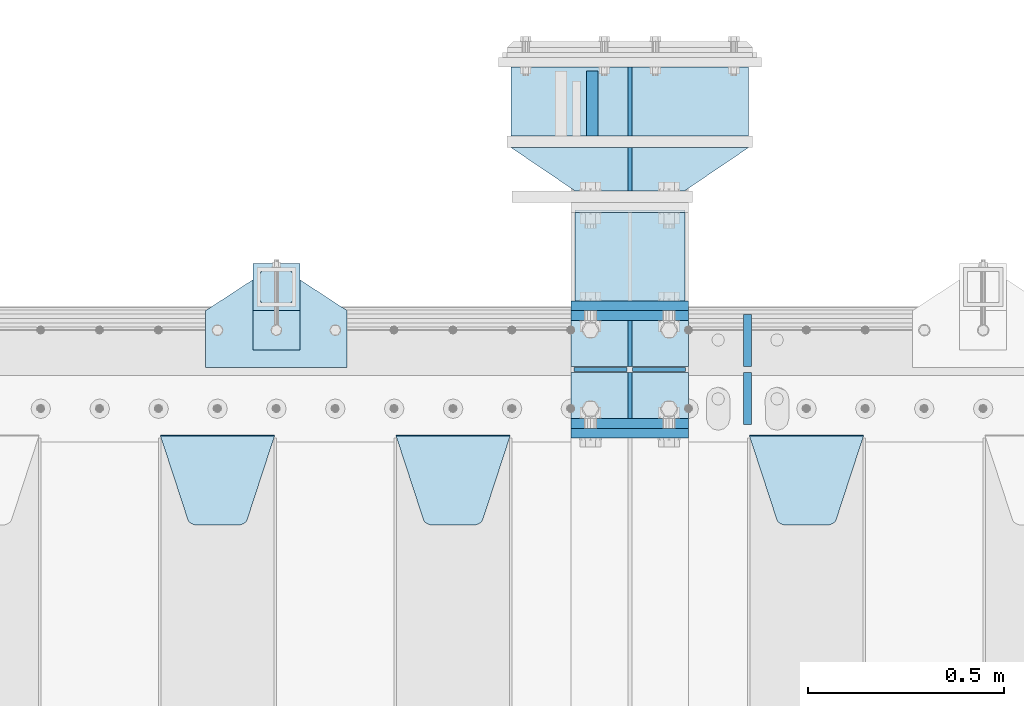
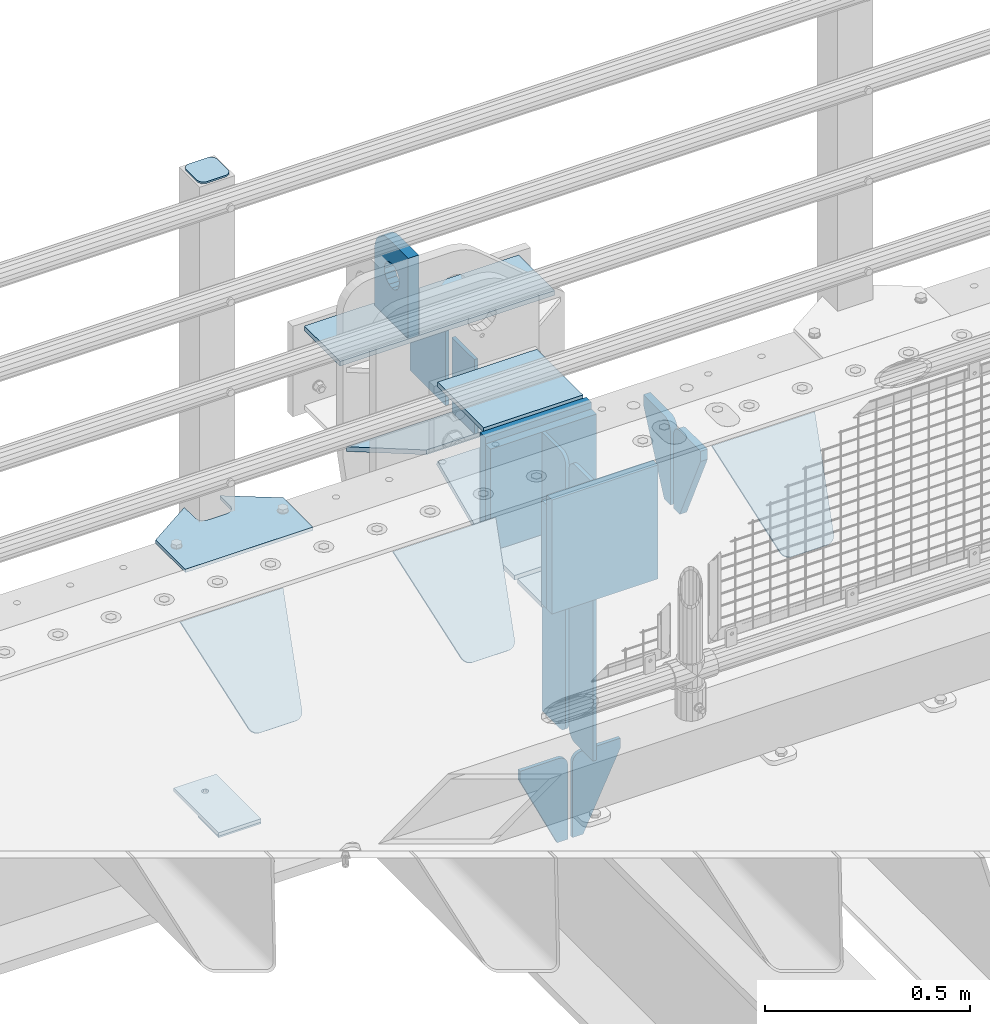
# One storey, part 186 of 208: 28 plates.
"""IFC2X3 building model written with IfcOpenShell, lengths in millimetres."""

import ifcopenshell
import ifcopenshell.guid

model = None  # the IFC model being written
_history = None  # IfcOwnerHistory: only IFC2X3 demands one
_inside = {}  # id of a spatial element -> (the spatial element, [elements in it])
_under = {}  # id of a project, library or spatial element -> (it, [spatial elements below it])
_declared = {}  # id of a project -> (the project, [libraries it declares])
_typed = {}  # id of a type object -> (the type object, [elements of that type])
_made_of = {}  # id of a material, layer set ... -> (it, [elements and type objects made of it])


def new_model(schema):
    """Start an empty IFC model of exactly this schema.

    Asked for "IFC4X3", IfcOpenShell would pick the latest addendum, in which some entities
    have other attributes; the version numbers below select the first issue.
    IFC2X3 requires an IfcOwnerHistory on every rooted entity: one is made here for all.
    """
    global model, _history
    if schema == "IFC4X3":
        model = ifcopenshell.file(schema_version=(4, 3, 0, 0))
    else:
        model = ifcopenshell.file(schema=schema)
    _inside.clear()
    _under.clear()
    _declared.clear()
    _typed.clear()
    _made_of.clear()
    _history = None
    if model.schema == "IFC2X3":
        org = make("IfcOrganization", Name="unknown")
        user = make(
            "IfcPersonAndOrganization",
            ThePerson=make("IfcPerson", FamilyName="unknown"),
            TheOrganization=org,
        )
        app = make(
            "IfcApplication",
            ApplicationDeveloper=org,
            Version="unknown",
            ApplicationFullName="unknown",
            ApplicationIdentifier="unknown",
        )
        _history = make(
            "IfcOwnerHistory",
            OwningUser=user,
            OwningApplication=app,
            ChangeAction="ADDED",
            CreationDate=0,
        )
    return model


def make(cls, **values):
    """One entity of the class cls with the attributes given. An attribute that is None is left unset."""
    return model.create_entity(
        cls, **{name: value for name, value in values.items() if value is not None}
    )


def rooted(cls, **values):
    """An entity with a GlobalId (a new one), such as an element, a storey or a relation."""
    return make(cls, GlobalId=ifcopenshell.guid.new(), OwnerHistory=_history, **values)


def si_unit(unit_type, name, prefix=None):
    """IfcSIUnit, for example si_unit("LENGTHUNIT", "METRE", prefix="MILLI")."""
    return make("IfcSIUnit", UnitType=unit_type, Prefix=prefix, Name=name)


def assignment(units):
    """IfcUnitAssignment: the units of a project."""
    return None if units is None else make("IfcUnitAssignment", Units=units)


def point(xyz):
    """IfcCartesianPoint."""
    return None if xyz is None else make("IfcCartesianPoint", Coordinates=xyz)


def direction(xyz):
    """IfcDirection."""
    return None if xyz is None else make("IfcDirection", DirectionRatios=xyz)


def frame(location, z_axis=None, x_axis=None):
    """IfcAxis2Placement3D, a coordinate frame: its origin and axes. An axis left out is left unset."""
    return make(
        "IfcAxis2Placement3D",
        Location=point(location),
        Axis=direction(z_axis),
        RefDirection=direction(x_axis),
    )


def origin_with_axes():
    """The frame at (0, 0, 0) with the z axis (0, 0, 1) and the x axis (1, 0, 0) written out."""
    return frame((0.0, 0.0, 0.0), z_axis=(0.0, 0.0, 1.0), x_axis=(1.0, 0.0, 0.0))


def place(relative_to, where):
    """IfcLocalPlacement: puts the frame where relative to a parent placement (None: the world)."""
    return make(
        "IfcLocalPlacement", PlacementRelTo=relative_to, RelativePlacement=where
    )


def context(
    kind, dimensions, precision=None, world=None, true_north=None, identifier=None
):
    """IfcGeometricRepresentationContext, for example the 3D "Model" context."""
    return make(
        "IfcGeometricRepresentationContext",
        ContextIdentifier=identifier,
        ContextType=kind,
        CoordinateSpaceDimension=dimensions,
        Precision=precision,
        WorldCoordinateSystem=world,
        TrueNorth=true_north,
    )


def subcontext(parent, identifier, kind, view, scale=None):
    """IfcGeometricRepresentationSubContext, for example "Body" below "Model"."""
    return make(
        "IfcGeometricRepresentationSubContext",
        ContextIdentifier=identifier,
        ContextType=kind,
        ParentContext=parent,
        TargetScale=scale,
        TargetView=view,
    )


def project(units=None, contexts=None):
    """IfcProject with its units and contexts."""
    return rooted(
        "IfcProject",
        Name="project",
        RepresentationContexts=contexts,
        UnitsInContext=assignment(units),
    )


def spatial(cls, under=None, at=None, **own):
    """A site, building, storey or space (cls), placed at a placement, below another one or the project."""
    s = rooted(cls, ObjectPlacement=at, **own)
    if under is not None:
        _under.setdefault(under.id(), (under, []))[1].append(s)
    return s


def faces_of(points, faces, orient=None, outer=None):
    """IfcFace entities. A face is a list of loops; a loop is a list of indices into points, from 0.

    orient and outer hold one flag for each loop. By default every Orientation is true, the
    first loop of a face is its IfcFaceOuterBound and the others are IfcFaceBound.
    """
    made = []
    for i, loops in enumerate(faces):
        bounds = []
        for j, loop in enumerate(loops):
            is_outer = j == 0 if outer is None else outer[i][j]
            bounds.append(
                make(
                    "IfcFaceOuterBound" if is_outer else "IfcFaceBound",
                    Bound=make("IfcPolyLoop", Polygon=[points[k] for k in loop]),
                    Orientation=True if orient is None else orient[i][j],
                )
            )
        made.append(make("IfcFace", Bounds=bounds))
    return made


def faceted_brep(points, faces, orient=None, outer=None, voids=None):
    """IfcFacetedBrep: a solid bounded by flat faces; with voids (closed shells), ...WithVoids."""
    shared = [point(p) for p in points]
    hull = make("IfcClosedShell", CfsFaces=faces_of(shared, faces, orient, outer))
    if voids is None:
        return make("IfcFacetedBrep", Outer=hull)
    return make(
        "IfcFacetedBrepWithVoids",
        Outer=hull,
        Voids=[
            make(cls, CfsFaces=faces_of(shared, fs, o, b)) for cls, fs, o, b in voids
        ],
    )


def shape(context_of_items, identifier, shape_type, items):
    """IfcShapeRepresentation: the items that make up one representation, for example the "Body"."""
    return make(
        "IfcShapeRepresentation",
        ContextOfItems=context_of_items,
        RepresentationIdentifier=identifier,
        RepresentationType=shape_type,
        Items=items,
    )


def material(Name=None, Category=None):
    """IfcMaterial."""
    return make("IfcMaterial", Name=Name, Category=Category)


def made_of(thing, what):
    """Note that an element or type object is made of a material, layer set ...; save() writes the relation."""
    if what is not None:
        _made_of.setdefault(what.id(), (what, []))[1].append(thing)
    return thing


def type_object(cls, material=None, **own):
    """A type object (cls), such as IfcWallType, which elements share."""
    return made_of(rooted(cls, **own), material)


def element(
    cls,
    number,
    at=None,
    inside=None,
    cuts=None,
    type_object=None,
    material=None,
    context=None,
    identifier="Body",
    shape_type=None,
    held_by="IfcProductDefinitionShape",
    body=None,
    shapes=None,
    **own,
):
    """One element of the class cls, such as IfcWall. Its Tag is "e" and its number.

    at: its placement. inside: the storey or other place that contains it. cuts: it is an
    opening in that element (IfcRelVoidsElement). A single representation is given by context,
    identifier, shape_type and body (its items); several are given by shapes. held_by: the class
    of the entity that holds the representations. save() writes the other relations.
    """
    e = rooted(cls, Tag="e%d" % number, ObjectPlacement=at, **own)
    if body is not None:
        shapes = [shape(context, identifier, shape_type, body)]
    if shapes is not None:
        e.Representation = make(held_by, Representations=shapes)
    if inside is not None:
        _inside.setdefault(inside.id(), (inside, []))[1].append(e)
    if cuts is not None:
        rooted(
            "IfcRelVoidsElement", RelatingBuildingElement=cuts, RelatedOpeningElement=e
        )
    if type_object is not None:
        _typed.setdefault(type_object.id(), (type_object, []))[1].append(e)
    return made_of(e, material)


def aggregate(whole, parts):
    """IfcRelAggregates: a whole, such as a stair, and the parts it consists of."""
    return rooted("IfcRelAggregates", RelatingObject=whole, RelatedObjects=parts)


def save(model, path):
    """Write the relations noted so far, then the file.

    IfcRelAggregates (storeys below a building ...), IfcRelContainedInSpatialStructure (elements
    in a storey), IfcRelDefinesByType, IfcRelAssociatesMaterial and IfcRelDeclares: one each for
    every whole, place, type object, material and project.
    """
    for whole, parts in _under.values():
        aggregate(whole, parts)
    for where, things in _inside.values():
        rooted(
            "IfcRelContainedInSpatialStructure",
            RelatedElements=things,
            RelatingStructure=where,
        )
    for kind, things in _typed.values():
        rooted("IfcRelDefinesByType", RelatedObjects=things, RelatingType=kind)
    for what, things in _made_of.values():
        rooted("IfcRelAssociatesMaterial", RelatedObjects=things, RelatingMaterial=what)
    for by, libraries in _declared.values():
        rooted("IfcRelDeclares", RelatingContext=by, RelatedDefinitions=libraries)
    model.write(path)


model = new_model("IFC2X3")

# Units and contexts
model_context = context("Model", 3, precision=1e-05, world=origin_with_axes())
body_context = subcontext(model_context, "Body", "Model", "MODEL_VIEW")
ifc_project = project(units=[si_unit("LENGTHUNIT", "METRE", prefix="MILLI"), si_unit("AREAUNIT", "SQUARE_METRE"), si_unit("VOLUMEUNIT", "CUBIC_METRE"), si_unit("MASSUNIT", "GRAM", prefix="KILO"), si_unit("TIMEUNIT", "SECOND"), si_unit("PLANEANGLEUNIT", "RADIAN"), si_unit("SOLIDANGLEUNIT", "STERADIAN"), si_unit("THERMODYNAMICTEMPERATUREUNIT", "DEGREE_CELSIUS"), si_unit("LUMINOUSINTENSITYUNIT", "LUMEN")], contexts=[model_context])

# Site, building, storey
site_placement = place(None, origin_with_axes())
site = spatial("IfcSite", under=ifc_project, at=site_placement, CompositionType="ELEMENT")
building_placement = place(site_placement, origin_with_axes())
building = spatial("IfcBuilding", under=site, at=building_placement, Name="Standard", CompositionType="ELEMENT")
storey_placement = place(building_placement, origin_with_axes())
storey = spatial("IfcBuildingStorey", under=building, at=storey_placement, Name="Undefined", CompositionType="ELEMENT", Elevation=0.0)

# Plates
ifc_material_1 = material(Name="STEEL/S355N")
plate_type_1 = type_object("IfcPlateType", PredefinedType="NOTDEFINED")
plate_1_placement = place(storey_placement, frame((-30340.0000000603, 6175.00000003457, -7.00001822199147), z_axis=(0.0, 1.0, 0.0), x_axis=(1.0, 0.0, 0.0)))
element("IfcPlate", 1, at=plate_1_placement, inside=storey, type_object=plate_type_1, material=ifc_material_1, context=body_context, shape_type="Brep", body=[
    faceted_brep([(0.0, -7.0, 0.0), (0.0, -7.0, 225.0), (0.0, 7.0, 225.0), (0.0, 7.0, 0.0), (280.0, -7.0, 225.0), (280.0, 7.0, 225.0), (280.0, -7.0, 0.0), (280.0, 7.0, 0.0)], [[[0, 1, 2, 3]], [[1, 4, 5, 2]], [[4, 6, 7, 5]], [[6, 0, 3, 7]], [[5, 7, 3, 2]], [[6, 4, 1, 0]]]),
])
plate_type_2 = type_object("IfcPlateType", PredefinedType="NOTDEFINED")
plate_2_placement = place(storey_placement, frame((-30200.0000000603, 6770.00000003457, -14.0000182219915), z_axis=(0.0, 0.0, -1.0), x_axis=(0.0, -1.0, 0.0)))
element("IfcPlate", 2, at=plate_2_placement, inside=storey, type_object=plate_type_2, material=ifc_material_1, context=body_context, shape_type="Brep", body=[
    faceted_brep([(0.0, -5.0, 0.0), (0.0, -5.0, 222.0), (0.0, 5.0, 222.0), (0.0, 5.0, 0.0), (175.0, -5.0, 222.0), (175.0, 5.0, 222.0), (175.0, -5.0, 0.0), (175.0, 5.0, 0.0)], [[[0, 1, 2, 3]], [[1, 4, 5, 2]], [[4, 6, 7, 5]], [[6, 0, 3, 7]], [[5, 7, 3, 2]], [[6, 4, 1, 0]]]),
])
plate_type_3 = type_object("IfcPlateType", PredefinedType="NOTDEFINED")
plate_3_placement = place(storey_placement, frame((-30295.5000000603, 6595.00000003457, -1.82219914677262e-05), z_axis=(0.0, 1.0, 0.0), x_axis=(0.0, 0.0, 1.0)))
element("IfcPlate", 3, at=plate_3_placement, inside=storey, type_object=plate_type_3, material=ifc_material_1, context=body_context, shape_type="Brep", body=[
    faceted_brep([(113.837049096103, -14.9999989400749, 106.162951053903), (113.837049096103, 15.0000010599251, 106.162950753903), (125.840713002497, 15.0000011401316, 114.183542552919), (125.840713002497, -14.9999988598684, 114.183542852919), (105.816457297088, -14.99999906011, 94.1592871475093), (105.816457297088, 15.00000093989, 94.1592868475093), (103.000000000005, -14.9999992017038, 80.000000150001), (103.000000000005, 15.0000007982962, 79.999999850001), (105.816457297088, -14.9999993432975, 65.8407131524926), (105.816457297088, 15.0000006567025, 65.8407128524926), (113.837049096103, -14.9999994633326, 53.8370492460988), (113.837049096103, 15.0000005366674, 53.8370489460988), (125.840713002497, -14.9999995435392, 45.8164574470834), (125.840713002497, 15.0000004564608, 45.8164571470834), (140.000000000005, -14.9999995717044, 43.000000150001), (140.000000000005, 15.0000004282956, 42.999999850001), (154.159286997514, -14.9999995435392, 45.8164574470834), (154.159286997514, 15.0000004564608, 45.8164571470834), (166.162950903908, -14.9999994633326, 53.8370492460988), (166.162950903908, 15.0000005366674, 53.8370489460988), (174.183542702923, -14.9999993432975, 65.8407131524928), (174.183542702923, 15.0000006567025, 65.8407128524927), (177.000000000005, -14.9999992017038, 80.000000150001), (177.000000000005, 15.0000007982962, 79.999999850001), (174.183542702923, -14.99999906011, 94.1592871475093), (174.183542702923, 15.00000093989, 94.1592868475093), (166.162950903908, -14.9999989400749, 106.162951053903), (166.162950903908, 15.0000010599251, 106.162950753903), (154.159286997514, -14.9999988598684, 114.183542852919), (154.159286997514, 15.0000011401316, 114.183542552919), (140.000000000005, -14.9999988317031, 117.000000150001), (140.000000000005, 15.0000011682969, 116.999999850001), (-1.40620068123098e-06, -15.0, 165.0), (170.0, -15.0, 165.0), (170.0, 15.0, 165.0), (-1.40620068123098e-06, 15.0, 165.0), (188.117333157176, -15.0, 162.614807840235), (188.117333157176, 15.0, 162.614807840235), (205.0, -15.0, 155.621778264911), (205.0, 15.0, 155.621778264911), (219.497474683058, -15.0, 144.497474683058), (219.497474683058, 15.0, 144.497474683058), (230.621778264911, -15.0, 130.0), (230.621778264911, 15.0, 130.0), (237.614807840235, -15.0, 113.117333157177), (237.614807840235, 15.0, 113.117333157177), (240.0, -15.0, 95.0), (240.0, 15.0, 95.0), (240.000015258789, -14.9999999999964, -2.06341610464733e-10), (240.000015258789, 15.0000000000036, -2.06341610464733e-10), (0.0, -15.0, 0.0), (0.0, 15.0, 0.0)], [[[0, 1, 2, 3]], [[4, 5, 1, 0]], [[6, 7, 5, 4]], [[8, 9, 7, 6]], [[10, 11, 9, 8]], [[12, 13, 11, 10]], [[14, 15, 13, 12]], [[16, 17, 15, 14]], [[18, 19, 17, 16]], [[20, 21, 19, 18]], [[22, 23, 21, 20]], [[24, 25, 23, 22]], [[26, 27, 25, 24]], [[28, 29, 27, 26]], [[30, 31, 29, 28]], [[3, 2, 31, 30]], [[32, 33, 34, 35]], [[33, 36, 37, 34]], [[36, 38, 39, 37]], [[38, 40, 41, 39]], [[40, 42, 43, 41]], [[42, 44, 45, 43]], [[44, 46, 47, 45]], [[46, 48, 49, 47]], [[48, 50, 51, 49]], [[34, 37, 39, 41, 43, 45, 47, 49, 51, 35], [19, 21, 23, 25, 27, 29, 31, 2, 1, 5, 7, 9, 11, 13, 15, 17]], [[50, 32, 35, 51]], [[48, 46, 44, 42, 40, 38, 36, 33, 32, 50], [10, 8, 6, 4, 0, 3, 30, 28, 26, 24, 22, 20, 18, 16, 14, 12]]]),
])
plate_type_4 = type_object("IfcPlateType", PredefinedType="NOTDEFINED")
plate_4_placement = place(storey_placement, frame((-30350.0000000603, 6162.50000003457, -340.000018221991), z_axis=(0.0, 0.0, 1.0), x_axis=(1.0, 0.0, 0.0)))
element("IfcPlate", 4, at=plate_4_placement, inside=storey, type_object=plate_type_4, material=ifc_material_1, context=body_context, shape_type="Brep", body=[
    faceted_brep([(0.0, -12.5, 0.0), (0.0, -12.5, 330.0), (0.0, 12.5, 330.0), (0.0, 12.5, 0.0), (300.0, -12.5, 330.0), (300.0, 12.5, 330.0), (300.0, -12.5, 0.0), (300.0, 12.5, 0.0)], [[[0, 1, 2, 3]], [[1, 4, 5, 2]], [[4, 6, 7, 5]], [[6, 0, 3, 7]], [[5, 7, 3, 2]], [[6, 4, 1, 0]]]),
])
for number, where, z_axis, x_axis in (
    (5, (-30350.0, 6137.5, -340.0), (0.0, 0.0, 1.0), (1.0, 0.0, 0.0)),
    (6, (-30350.0, 5862.5, -340.0), (0.0, 0.0, 1.0), (1.0, 0.0, 0.0)),
):
    element("IfcPlate", number, at=place(storey_placement, frame(where, z_axis=z_axis, x_axis=x_axis)), inside=storey, type_object=plate_type_4, material=ifc_material_1, context=body_context, shape_type="Brep", body=[
        faceted_brep([(0.0, -12.5, 0.0), (0.0, -12.5, 310.0), (0.0, 12.5, 310.0), (0.0, 12.5, 0.0), (300.0, -12.5, 310.0), (300.0, 12.5, 310.0), (300.0, -12.5, 0.0), (300.0, 12.5, 0.0)], [[[0, 1, 2, 3]], [[1, 4, 5, 2]], [[4, 6, 7, 5]], [[6, 0, 3, 7]], [[5, 7, 3, 2]], [[6, 4, 1, 0]]]),
    ])
plate_5_placement = place(storey_placement, frame((-30350.0, 5837.5, -340.000000000044), z_axis=(0.0, 0.0, 1.0), x_axis=(1.0, 0.0, 0.0)))
element("IfcPlate", 7, at=plate_5_placement, inside=storey, type_object=plate_type_4, material=ifc_material_1, context=body_context, shape_type="Brep", body=[
    faceted_brep([(0.0, -12.5, 0.0), (0.0, -12.5, 340.0), (0.0, 12.5, 340.0), (0.0, 12.5, 0.0), (300.0, -12.5, 340.0), (300.0, 12.5, 340.0), (300.0, -12.5, 0.0), (300.0, 12.5, 0.0)], [[[0, 1, 2, 3]], [[1, 4, 5, 2]], [[4, 6, 7, 5]], [[6, 0, 3, 7]], [[5, 7, 3, 2]], [[6, 4, 1, 0]]]),
])
plate_type_5 = type_object("IfcPlateType", PredefinedType="NOTDEFINED")
for number, where, z_axis, x_axis in (
    (8, (-30350.0, 5992.0, -343.0), (0.0, -1.0, 0.0), (1.0, 0.0, 0.0)),
    (9, (-30350.0, 6008.0, -343.0), (0.0, 1.0, 0.0), (1.0, 0.0, 0.0)),
):
    element("IfcPlate", number, at=place(storey_placement, frame(where, z_axis=z_axis, x_axis=x_axis)), inside=storey, type_object=plate_type_5, material=ifc_material_1, context=body_context, shape_type="Brep", body=[
        faceted_brep([(0.0, -7.0, 0.0), (0.0, -7.0, 117.0), (0.0, 7.0, 117.0), (0.0, 7.0, 0.0), (300.0, -7.0, 117.0), (300.0, 7.0, 117.0), (300.0, -7.0, 0.0), (300.0, 7.0, 0.0)], [[[0, 1, 2, 3]], [[1, 4, 5, 2]], [[4, 6, 7, 5]], [[6, 0, 3, 7]], [[5, 7, 3, 2]], [[6, 4, 1, 0]]]),
    ])
plate_type_6 = type_object("IfcPlateType", PredefinedType="NOTDEFINED")
for number, where, z_axis, x_axis in (
    (10, (-30200.0, 5992.0, -350.0), (0.0, 0.0, -1.0), (0.0, -1.0, 0.0)),
    (11, (-30200.0, 6008.0, -350.0), (0.0, 0.0, -1.0), (0.0, 1.0, 0.0)),
):
    element("IfcPlate", number, at=place(storey_placement, frame(where, z_axis=z_axis, x_axis=x_axis)), inside=storey, type_object=plate_type_6, material=ifc_material_1, context=body_context, shape_type="Brep", body=[
        faceted_brep([(0.0, -5.0, 0.0), (0.0, -5.0, 480.0), (0.0, 5.0, 480.0), (0.0, 5.0, 0.0), (0.455767409634063, -5.0, 485.209445330008), (0.455767409634063, 5.0, 485.209445330008), (1.80922137642301, -5.0, 490.26060429977), (1.80922137642301, 5.0, 490.26060429977), (4.01923788646673, -5.0, 495.0), (4.01923788646673, 5.0, 495.0), (7.01866670643085, -5.0, 499.283628290596), (7.01866670643085, 5.0, 499.283628290596), (10.7163717094036, -5.0, 502.981333293569), (10.7163717094036, 5.0, 502.981333293569), (15.0, -5.0, 505.980762113533), (15.0, 5.0, 505.980762113533), (19.7393957002296, -5.0, 508.190778623577), (19.7393957002296, 5.0, 508.190778623577), (24.7905546699922, -5.0, 509.544232590366), (24.7905546699922, 5.0, 509.544232590366), (30.0, -5.0, 510.0), (30.0, 5.0, 510.0), (117.0, -5.0, 510.0), (117.0, 5.0, 510.0), (117.0, -5.0, 0.0), (117.0, 5.0, 0.0)], [[[0, 1, 2, 3]], [[1, 4, 5, 2]], [[4, 6, 7, 5]], [[6, 8, 9, 7]], [[8, 10, 11, 9]], [[10, 12, 13, 11]], [[12, 14, 15, 13]], [[14, 16, 17, 15]], [[16, 18, 19, 17]], [[18, 20, 21, 19]], [[20, 22, 23, 21]], [[22, 24, 25, 23]], [[24, 0, 3, 25]], [[5, 7, 9, 11, 13, 15, 17, 19, 21, 23, 25, 3, 2]], [[24, 22, 20, 18, 16, 14, 12, 10, 8, 6, 4, 1, 0]]]),
    ])
for number, where, z_axis, x_axis in (
    (12, (-30200.0, 6008.0, -30.0), (0.0, 0.0, -1.0), (0.0, 1.0, 0.0)),
    (13, (-30200.0, 5992.0, -30.0), (0.0, 0.0, -1.0), (0.0, -1.0, 0.0)),
):
    element("IfcPlate", number, at=place(storey_placement, frame(where, z_axis=z_axis, x_axis=x_axis)), inside=storey, type_object=plate_type_6, material=ifc_material_1, context=body_context, shape_type="Brep", body=[
        faceted_brep([(0.0, -5.0, 30.0), (0.0, -5.0, 306.0), (0.0, 5.0, 306.0), (0.0, 5.0, 30.0), (117.0, -5.0, 306.0), (117.0, 5.0, 306.0), (117.0, -5.0, 0.0), (117.0, 5.0, 0.0), (30.0, -5.0, 0.0), (30.0, 5.0, 0.0), (24.7905546699922, -5.0, 0.455767409633758), (24.7905546699922, 5.0, 0.455767409633758), (19.7393957002296, -5.0, 1.80922137642275), (19.7393957002296, 5.0, 1.80922137642275), (15.0, -5.0, 4.01923788646684), (15.0, 5.0, 4.01923788646684), (10.7163717094036, -5.0, 7.01866670643066), (10.7163717094036, 5.0, 7.01866670643066), (7.01866670643085, -5.0, 10.7163717094038), (7.01866670643085, 5.0, 10.7163717094038), (4.01923788646673, -5.0, 15.0), (4.01923788646673, 5.0, 15.0), (1.80922137642301, -5.0, 19.7393957002299), (1.80922137642301, 5.0, 19.7393957002299), (0.455767409634063, -5.0, 24.7905546699921), (0.455767409634063, 5.0, 24.7905546699921)], [[[0, 1, 2, 3]], [[1, 4, 5, 2]], [[4, 6, 7, 5]], [[6, 8, 9, 7]], [[8, 10, 11, 9]], [[10, 12, 13, 11]], [[12, 14, 15, 13]], [[14, 16, 17, 15]], [[16, 18, 19, 17]], [[18, 20, 21, 19]], [[20, 22, 23, 21]], [[22, 24, 25, 23]], [[24, 0, 3, 25]], [[5, 7, 9, 11, 13, 15, 17, 19, 21, 23, 25, 3, 2]], [[24, 22, 20, 18, 16, 14, 12, 10, 8, 6, 4, 1, 0]]]),
    ])
plate_type_7 = type_object("IfcPlateType", PredefinedType="NOTDEFINED")
for number, where, z_axis, x_axis in (
    (14, (-30206.4999999426, 5999.99999996507, -915.000018222557), (0.0, 0.0, -1.0), (-1.0, 0.0, 0.0)),
    (15, (-30193.4999999426, 5999.99999996507, -915.000018222557), (0.0, 0.0, -1.0), (1.0, 0.0, 0.0)),
):
    element("IfcPlate", number, at=place(storey_placement, frame(where, z_axis=z_axis, x_axis=x_axis)), inside=storey, type_object=plate_type_7, material=ifc_material_1, context=body_context, shape_type="Brep", body=[
        faceted_brep([(0.0, -5.0, 27.0), (0.0, -5.0, 250.0), (0.0, 5.0, 250.0), (0.0, 5.0, 27.0), (30.0, -5.0, 250.0), (30.0, 5.0, 250.0), (135.0, -5.0, 30.0), (135.0, 5.0, 30.0), (135.0, -5.0, 0.0), (135.0, 5.0, 0.0), (27.0, -5.0, 0.0), (27.0, 5.0, 0.0), (22.3114992029914, -5.0, 0.410190668670339), (22.3114992029914, 5.0, 0.410190668670339), (17.7654561302079, -5.0, 1.62829923878041), (17.7654561302079, 5.0, 1.62829923878041), (13.5, -5.0, 3.61731409782021), (13.5, 5.0, 3.61731409782021), (9.64473453846222, -5.0, 6.31680003578765), (9.64473453846222, 5.0, 6.31680003578765), (6.31680003578731, -5.0, 9.64473453846347), (6.31680003578731, 5.0, 9.64473453846347), (3.61731409782078, -5.0, 13.5), (3.61731409782078, 5.0, 13.5), (1.62829923877871, -5.0, 17.765456130207), (1.62829923877871, 5.0, 17.765456130207), (0.410190668670111, -5.0, 22.3114992029929), (0.410190668670111, 5.0, 22.3114992029929)], [[[0, 1, 2, 3]], [[1, 4, 5, 2]], [[4, 6, 7, 5]], [[6, 8, 9, 7]], [[8, 10, 11, 9]], [[10, 12, 13, 11]], [[12, 14, 15, 13]], [[14, 16, 17, 15]], [[16, 18, 19, 17]], [[18, 20, 21, 19]], [[20, 22, 23, 21]], [[22, 24, 25, 23]], [[24, 26, 27, 25]], [[26, 0, 3, 27]], [[5, 7, 9, 11, 13, 15, 17, 19, 21, 23, 25, 27, 3, 2]], [[26, 24, 22, 20, 18, 16, 14, 12, 10, 8, 6, 4, 1, 0]]]),
    ])
plate_type_8 = type_object("IfcPlateType", PredefinedType="NOTDEFINED")
plate_6_placement = place(storey_placement, frame((-29895.0, 5831.76776695596, -1.76776695296758), z_axis=(0.0, -0.707106781186548, -0.707106781186547), x_axis=(1.0, 0.0, 0.0)))
element("IfcPlate", 16, at=plate_6_placement, inside=storey, type_object=plate_type_8, material=ifc_material_1, context=body_context, shape_type="Brep", body=[
    faceted_brep([(0.0, -2.5, 0.0), (69.345504679477, -2.5, 300.17173142483), (69.345504679477, 2.5, 300.17173142483), (0.0, 2.5, 0.0), (70.9274061199576, -2.5, 304.897442415399), (70.9274061199576, 2.5, 304.8974424154), (73.3818627772307, -2.5, 309.234538108527), (73.3818627772307, 2.5, 309.234538108527), (76.6187032999551, -2.5, 313.023683126103), (76.6187032999551, 2.5, 313.023683126103), (80.5190132704993, -2.5, 316.125672595371), (80.5190132704993, 2.5, 316.125672595371), (84.9395038596849, -2.5, 318.426546230476), (84.9395038596849, 2.50000000000091, 318.426546230476), (89.7177759439219, -2.5, 319.841774983275), (89.7177759439219, 2.50000000000091, 319.841774983275), (94.678286292652, -2.49999999999909, 320.319366455078), (94.678286292652, 2.5, 320.319366455078), (195.321713707348, -2.49999999999909, 320.319366455078), (195.321713707348, 2.5, 320.319366455078), (200.282224056078, -2.5, 319.841774983275), (200.282224056078, 2.5, 319.841774983274), (205.060496140315, -2.5, 318.426546230475), (205.060496140315, 2.5, 318.426546230475), (209.480986729501, -2.5, 316.125672595371), (209.480986729501, 2.50000000000091, 316.125672595371), (213.381296700045, -2.5, 313.023683126102), (213.381296700045, 2.5, 313.023683126102), (216.618137222769, -2.5, 309.234538108526), (216.618137222769, 2.5, 309.234538108527), (219.072593880042, -2.5, 304.897442415399), (219.072593880042, 2.5, 304.897442415399), (220.654495320523, -2.5, 300.17173142483), (220.654495320523, 2.5, 300.17173142483), (290.0, -2.5, 0.0), (290.0, 2.5, 0.0)], [[[0, 1, 2, 3]], [[1, 4, 5, 2]], [[4, 6, 7, 5]], [[6, 8, 9, 7]], [[8, 10, 11, 9]], [[10, 12, 13, 11]], [[12, 14, 15, 13]], [[14, 16, 17, 15]], [[16, 18, 19, 17]], [[18, 20, 21, 19]], [[20, 22, 23, 21]], [[22, 24, 25, 23]], [[24, 26, 27, 25]], [[26, 28, 29, 27]], [[28, 30, 31, 29]], [[30, 32, 33, 31]], [[32, 34, 35, 33]], [[34, 0, 3, 35]], [[5, 7, 9, 11, 13, 15, 17, 19, 21, 23, 25, 27, 29, 31, 33, 35, 3, 2]], [[34, 32, 30, 28, 26, 24, 22, 20, 18, 16, 14, 12, 10, 8, 6, 4, 1, 0]]]),
])
plate_7_placement = place(storey_placement, frame((-30795.0, 5831.76776695596, -1.76776695296758), z_axis=(0.0, -0.707106781186548, -0.707106781186547), x_axis=(1.0, 0.0, 0.0)))
element("IfcPlate", 17, at=plate_7_placement, inside=storey, type_object=plate_type_8, material=ifc_material_1, context=body_context, shape_type="Brep", body=[
    faceted_brep([(0.0, -2.5, 0.0), (69.345504679477, -2.5, 300.17173142483), (69.345504679477, 2.5, 300.17173142483), (0.0, 2.5, 0.0), (70.9274061199576, -2.5, 304.897442415399), (70.9274061199576, 2.5, 304.8974424154), (73.3818627772307, -2.5, 309.234538108527), (73.3818627772307, 2.5, 309.234538108527), (76.6187032999551, -2.5, 313.023683126103), (76.6187032999551, 2.5, 313.023683126103), (80.5190132704993, -2.5, 316.125672595371), (80.5190132704993, 2.5, 316.125672595371), (84.9395038596849, -2.5, 318.426546230476), (84.9395038596849, 2.50000000000091, 318.426546230476), (89.7177759439219, -2.5, 319.841774983275), (89.7177759439219, 2.50000000000091, 319.841774983275), (94.678286292652, -2.49999999999909, 320.319366455078), (94.678286292652, 2.5, 320.319366455078), (195.321713707348, -2.49999999999909, 320.319366455078), (195.321713707348, 2.5, 320.319366455078), (200.282224056078, -2.5, 319.841774983275), (200.282224056078, 2.5, 319.841774983274), (205.060496140315, -2.5, 318.426546230475), (205.060496140315, 2.5, 318.426546230475), (209.480986729501, -2.5, 316.125672595371), (209.480986729501, 2.50000000000091, 316.125672595371), (213.381296700045, -2.5, 313.023683126102), (213.381296700045, 2.5, 313.023683126102), (216.618137222769, -2.5, 309.234538108526), (216.618137222769, 2.5, 309.234538108527), (219.072593880042, -2.5, 304.897442415399), (219.072593880042, 2.5, 304.897442415399), (220.654495320523, -2.5, 300.17173142483), (220.654495320523, 2.5, 300.17173142483), (290.0, -2.5, 0.0), (290.0, 2.5, 0.0)], [[[0, 1, 2, 3]], [[1, 4, 5, 2]], [[4, 6, 7, 5]], [[6, 8, 9, 7]], [[8, 10, 11, 9]], [[10, 12, 13, 11]], [[12, 14, 15, 13]], [[14, 16, 17, 15]], [[16, 18, 19, 17]], [[18, 20, 21, 19]], [[20, 22, 23, 21]], [[22, 24, 25, 23]], [[24, 26, 27, 25]], [[26, 28, 29, 27]], [[28, 30, 31, 29]], [[30, 32, 33, 31]], [[32, 34, 35, 33]], [[34, 0, 3, 35]], [[5, 7, 9, 11, 13, 15, 17, 19, 21, 23, 25, 27, 29, 31, 33, 35, 3, 2]], [[34, 32, 30, 28, 26, 24, 22, 20, 18, 16, 14, 12, 10, 8, 6, 4, 1, 0]]]),
])
plate_8_placement = place(storey_placement, frame((-31395.0, 5831.76776695596, -1.76776695296758), z_axis=(0.0, -0.707106781186548, -0.707106781186547), x_axis=(1.0, 0.0, 0.0)))
element("IfcPlate", 18, at=plate_8_placement, inside=storey, type_object=plate_type_8, material=ifc_material_1, context=body_context, shape_type="Brep", body=[
    faceted_brep([(0.0, -2.5, 0.0), (69.345504679477, -2.5, 300.17173142483), (69.345504679477, 2.5, 300.17173142483), (0.0, 2.5, 0.0), (70.9274061199576, -2.5, 304.897442415399), (70.9274061199576, 2.5, 304.8974424154), (73.3818627772307, -2.5, 309.234538108527), (73.3818627772307, 2.5, 309.234538108527), (76.6187032999551, -2.5, 313.023683126103), (76.6187032999551, 2.5, 313.023683126103), (80.5190132704993, -2.5, 316.125672595371), (80.5190132704993, 2.5, 316.125672595371), (84.9395038596849, -2.5, 318.426546230476), (84.9395038596849, 2.50000000000091, 318.426546230476), (89.7177759439219, -2.5, 319.841774983275), (89.7177759439219, 2.50000000000091, 319.841774983275), (94.678286292652, -2.49999999999909, 320.319366455078), (94.678286292652, 2.5, 320.319366455078), (195.321713707348, -2.49999999999909, 320.319366455078), (195.321713707348, 2.5, 320.319366455078), (200.282224056078, -2.5, 319.841774983275), (200.282224056078, 2.5, 319.841774983274), (205.060496140315, -2.5, 318.426546230475), (205.060496140315, 2.5, 318.426546230475), (209.480986729501, -2.5, 316.125672595371), (209.480986729501, 2.50000000000091, 316.125672595371), (213.381296700045, -2.5, 313.023683126102), (213.381296700045, 2.5, 313.023683126102), (216.618137222769, -2.5, 309.234538108526), (216.618137222769, 2.5, 309.234538108527), (219.072593880042, -2.5, 304.897442415399), (219.072593880042, 2.5, 304.897442415399), (220.654495320523, -2.5, 300.17173142483), (220.654495320523, 2.5, 300.17173142483), (290.0, -2.5, 0.0), (290.0, 2.5, 0.0)], [[[0, 1, 2, 3]], [[1, 4, 5, 2]], [[4, 6, 7, 5]], [[6, 8, 9, 7]], [[8, 10, 11, 9]], [[10, 12, 13, 11]], [[12, 14, 15, 13]], [[14, 16, 17, 15]], [[16, 18, 19, 17]], [[18, 20, 21, 19]], [[20, 22, 23, 21]], [[22, 24, 25, 23]], [[24, 26, 27, 25]], [[26, 28, 29, 27]], [[28, 30, 31, 29]], [[30, 32, 33, 31]], [[32, 34, 35, 33]], [[34, 0, 3, 35]], [[5, 7, 9, 11, 13, 15, 17, 19, 21, 23, 25, 27, 29, 31, 33, 35, 3, 2]], [[34, 32, 30, 28, 26, 24, 22, 20, 18, 16, 14, 12, 10, 8, 6, 4, 1, 0]]]),
])
plate_type_9 = type_object("IfcPlateType", PredefinedType="NOTDEFINED")
for number, where, z_axis, x_axis in (
    (19, (-29900.0, 5860.0, -30.0), (0.0, 0.0, -1.0), (0.0, 1.0, 0.0)),
    (20, (-29900.0, 6140.0, -30.0), (0.0, 0.0, -1.0), (0.0, -1.0, 0.0)),
):
    element("IfcPlate", number, at=place(storey_placement, frame(where, z_axis=z_axis, x_axis=x_axis)), inside=storey, type_object=plate_type_9, material=ifc_material_1, context=body_context, shape_type="Brep", body=[
        faceted_brep([(0.0, -10.0, 0.0), (0.0, -10.0, 30.0), (0.0, 10.0, 30.0), (0.0, 10.0, 0.0), (102.0, -10.0, 250.0), (102.0, 10.0, 250.0), (132.0, -10.0, 250.0), (132.0, 10.0, 250.0), (132.0, -10.0, 30.0), (132.0, 10.0, 30.0), (131.544232590366, -10.0, 24.790554669992), (131.544232590366, 10.0, 24.790554669992), (130.190778623577, -10.0, 19.7393957002299), (130.190778623577, 10.0, 19.7393957002299), (127.980762113533, -10.0, 15.0), (127.980762113533, 10.0, 15.0), (124.981333293569, -10.0, 10.7163717094038), (124.981333293569, 10.0, 10.7163717094038), (121.283628290596, -10.0, 7.01866670643062), (121.283628290596, 10.0, 7.01866670643062), (117.0, -10.0, 4.01923788646684), (117.0, 10.0, 4.01923788646684), (112.26060429977, -10.0, 1.80922137642278), (112.26060429977, 10.0, 1.80922137642278), (107.209445330008, -10.0, 0.455767409633722), (107.209445330008, 10.0, 0.455767409633722), (102.0, -10.0, 0.0), (102.0, 10.0, 0.0)], [[[0, 1, 2, 3]], [[1, 4, 5, 2]], [[4, 6, 7, 5]], [[6, 8, 9, 7]], [[8, 10, 11, 9]], [[10, 12, 13, 11]], [[12, 14, 15, 13]], [[14, 16, 17, 15]], [[16, 18, 19, 17]], [[18, 20, 21, 19]], [[20, 22, 23, 21]], [[22, 24, 25, 23]], [[24, 26, 27, 25]], [[26, 0, 3, 27]], [[5, 7, 9, 11, 13, 15, 17, 19, 21, 23, 25, 27, 3, 2]], [[26, 24, 22, 20, 18, 16, 14, 12, 10, 8, 6, 4, 1, 0]]]),
    ])
ifc_material_2 = material(Name="STEEL/S355J2")
plate_type_10 = type_object("IfcPlateType", PredefinedType="NOTDEFINED")
plate_9_placement = place(storey_placement, frame((-31280.0, 6005.0, 5.00000000004911), z_axis=(0.0, 1.0, 0.0), x_axis=(1.0, 0.0, 0.0)))
element("IfcPlate", 21, at=plate_9_placement, inside=storey, type_object=plate_type_10, material=ifc_material_2, context=body_context, shape_type="Brep", body=[
    faceted_brep([(0.0, -5.0, 0.0), (2.31396552408114e-06, -5.0, 145.0), (2.31396552408114e-06, 5.0, 145.0), (0.0, 5.0, 0.0), (130.0, -5.0, 230.0), (130.0, 5.0, 230.0), (130.0, -5.0, 180.0), (130.0, 5.0, 180.0), (130.48036798992, -5.0, 175.122741949597), (130.48036798992, 5.0, 175.122741949597), (131.903011687216, -5.0, 170.432914190873), (131.903011687216, 5.0, 170.432914190873), (134.213259692435, -5.0, 166.11074417451), (134.213259692435, 5.0, 166.11074417451), (137.322330470335, -5.0, 162.322330470336), (137.322330470335, 5.0, 162.322330470336), (141.110744174512, -5.0, 159.213259692437), (141.110744174512, 5.0, 159.213259692437), (145.432914190871, -5.0, 156.903011687218), (145.432914190871, 5.0, 156.903011687218), (150.122741949595, -5.0, 155.48036798992), (150.122741949595, 5.0, 155.48036798992), (155.0, -5.0, 155.0), (155.0, 5.0, 155.0), (205.0, -5.0, 155.0), (205.0, 5.0, 155.0), (209.877258050405, -5.0, 155.48036798992), (209.877258050405, 5.0, 155.48036798992), (214.567085809129, -5.0, 156.903011687218), (214.567085809129, 5.0, 156.903011687218), (218.889255825488, -5.0, 159.213259692437), (218.889255825488, 5.0, 159.213259692437), (222.677669529665, -5.0, 162.322330470336), (222.677669529665, 5.0, 162.322330470336), (225.786740307565, -5.0, 166.11074417451), (225.786740307565, 5.0, 166.11074417451), (228.096988312784, -5.0, 170.432914190873), (228.096988312784, 5.0, 170.432914190873), (229.51963201008, -5.0, 175.122741949597), (229.51963201008, 5.0, 175.122741949597), (230.0, -5.0, 180.0), (230.0, 5.0, 180.0), (230.0, -5.0, 230.0), (230.0, 5.0, 230.0), (360.0, -5.0, 145.0), (360.0, 5.0, 145.0), (360.0, -5.0, -7.27595761418343e-12), (360.0, 5.0, -7.27595761418343e-12)], [[[0, 1, 2, 3]], [[1, 4, 5, 2]], [[4, 6, 7, 5]], [[6, 8, 9, 7]], [[8, 10, 11, 9]], [[10, 12, 13, 11]], [[12, 14, 15, 13]], [[14, 16, 17, 15]], [[16, 18, 19, 17]], [[18, 20, 21, 19]], [[20, 22, 23, 21]], [[22, 24, 25, 23]], [[24, 26, 27, 25]], [[26, 28, 29, 27]], [[28, 30, 31, 29]], [[30, 32, 33, 31]], [[32, 34, 35, 33]], [[34, 36, 37, 35]], [[36, 38, 39, 37]], [[38, 40, 41, 39]], [[40, 42, 43, 41]], [[42, 44, 45, 43]], [[44, 46, 47, 45]], [[46, 0, 3, 47]], [[5, 7, 9, 11, 13, 15, 17, 19, 21, 23, 25, 27, 29, 31, 33, 35, 37, 39, 41, 43, 45, 47, 3, 2]], [[46, 44, 42, 40, 38, 36, 34, 32, 30, 28, 26, 24, 22, 20, 18, 16, 14, 12, 10, 8, 6, 4, 1, 0]]]),
])
plate_type_11 = type_object("IfcPlateType", PredefinedType="NOTDEFINED")
plate_10_placement = place(storey_placement, frame((-31159.9999999999, 6050.00000000021, -850.000000000002), z_axis=(0.0, 1.0, 0.0), x_axis=(1.0, 0.0, 0.0)))
element("IfcPlate", 22, at=plate_10_placement, inside=storey, type_object=plate_type_11, material=ifc_material_2, context=body_context, shape_type="Brep", body=[
    faceted_brep([(66.3639610305399, -5.0, 163.636038969112), (66.3639610305399, 5.0, 163.636038969112), (59.9999999998618, 5.0, 160.999999999791), (59.9999999998618, -5.0, 160.999999999791), (53.6360389691836, 5.0, 163.636038969112), (53.6360389691836, -5.0, 163.636038969112), (50.9999999998618, 5.0, 169.999999999791), (50.9999999998618, -5.0, 169.999999999791), (53.6360389691836, 5.0, 176.36396103047), (53.6360389691836, -5.0, 176.36396103047), (59.9999999998618, 5.0, 178.999999999791), (59.9999999998618, -5.0, 178.999999999791), (66.3639610305399, 5.0, 176.36396103047), (66.3639610305399, -5.0, 176.36396103047), (68.9999999998618, 5.0, 169.999999999791), (68.9999999998618, -5.0, 169.999999999791), (120.0, -5.0, 0.0), (120.0, -5.0, 220.0), (0.0, -5.0, 220.0), (0.0, -5.0, 0.0), (0.0, 5.0, 0.0), (120.0, 5.0, 0.0), (120.0, 5.0, 220.0), (0.0, 5.0, 220.0)], [[[0, 1, 2, 3]], [[3, 2, 4, 5]], [[5, 4, 6, 7]], [[7, 6, 8, 9]], [[9, 8, 10, 11]], [[11, 10, 12, 13]], [[13, 12, 14, 15]], [[15, 14, 1, 0]], [[16, 17, 18, 19], [3, 5, 7, 9, 11, 13, 15, 0]], [[16, 19, 20, 21]], [[17, 16, 21, 22]], [[18, 17, 22, 23]], [[19, 18, 23, 20]], [[22, 21, 20, 23], [10, 8, 6, 4, 2, 1, 14, 12]]]),
])
plate_type_12 = type_object("IfcPlateType", PredefinedType="NOTDEFINED")
plate_11_placement = place(storey_placement, frame((-31055.9999999999, 6166.00000000021, 1012.50000000001), z_axis=(0.0, 1.0, 0.0), x_axis=(-1.0, 0.0, 0.0)))
element("IfcPlate", 23, at=plate_11_placement, inside=storey, type_object=plate_type_12, material=ifc_material_2, context=body_context, shape_type="Brep", body=[
    faceted_brep([(0.0, -2.5, 19.0), (0.0, -2.5, 69.0), (0.0, 2.5, 69.0), (0.0, 2.5, 19.0), (0.476369668544066, -2.5, 73.2278977451697), (0.476369668544066, 2.5, 73.2278977451697), (1.88159150985302, -2.5, 77.2437910432336), (1.88159150985302, 2.5, 77.2437910432336), (4.14520183310742, -2.5, 80.8463062353158), (4.14520183310742, 2.5, 80.8463062353158), (7.15369376468516, -2.5, 83.8547981668926), (7.15369376468516, 2.5, 83.8547981668926), (10.7562089567655, -2.5, 86.1184084901461), (10.7562089567655, 2.5, 86.1184084901461), (14.7721022548285, -2.5, 87.523630331455), (14.7721022548285, 2.5, 87.523630331455), (19.0, -2.5, 88.0), (19.0, 2.5, 88.0), (69.0, -2.5, 88.0), (69.0, 2.5, 88.0), (73.2278977451715, -2.5, 87.523630331455), (73.2278977451715, 2.5, 87.523630331455), (77.2437910432345, -2.5, 86.1184084901461), (77.2437910432345, 2.5, 86.1184084901461), (80.8463062353148, -2.5, 83.8547981668926), (80.8463062353148, 2.5, 83.8547981668926), (83.8547981668926, -2.5, 80.8463062353158), (83.8547981668926, 2.5, 80.8463062353158), (86.118408490147, -2.5, 77.2437910432336), (86.118408490147, 2.5, 77.2437910432336), (87.5236303314559, -2.5, 73.2278977451697), (87.5236303314559, 2.5, 73.2278977451697), (88.0, -2.5, 69.0), (88.0, 2.5, 69.0), (88.0, -2.5, 19.0), (88.0, 2.5, 19.0), (87.5236303314559, -2.5, 14.7721022548303), (87.5236303314559, 2.5, 14.7721022548303), (86.118408490147, -2.5, 10.7562089567664), (86.118408490147, 2.5, 10.7562089567664), (83.8547981668926, -2.5, 7.15369376468425), (83.8547981668926, 2.5, 7.15369376468425), (80.8463062353148, -2.5, 4.14520183310742), (80.8463062353148, 2.5, 4.14520183310742), (77.2437910432345, -2.5, 1.88159150985393), (77.2437910432345, 2.5, 1.88159150985393), (73.2278977451715, -2.5, 0.476369668544976), (73.2278977451715, 2.5, 0.476369668544976), (69.0, -2.5, 0.0), (69.0, 2.5, 0.0), (19.0, -2.5, 0.0), (19.0, 2.5, 0.0), (14.7721022548285, -2.5, 0.476369668544976), (14.7721022548285, 2.5, 0.476369668544976), (10.7562089567655, -2.5, 1.88159150985393), (10.7562089567655, 2.5, 1.88159150985393), (7.15369376468516, -2.5, 4.14520183310742), (7.15369376468516, 2.5, 4.14520183310742), (4.14520183310742, -2.5, 7.15369376468425), (4.14520183310742, 2.5, 7.15369376468425), (1.88159150985302, -2.5, 10.7562089567664), (1.88159150985302, 2.5, 10.7562089567664), (0.476369668544066, -2.5, 14.7721022548303), (0.476369668544066, 2.5, 14.7721022548303)], [[[0, 1, 2, 3]], [[1, 4, 5, 2]], [[4, 6, 7, 5]], [[6, 8, 9, 7]], [[8, 10, 11, 9]], [[10, 12, 13, 11]], [[12, 14, 15, 13]], [[14, 16, 17, 15]], [[16, 18, 19, 17]], [[18, 20, 21, 19]], [[20, 22, 23, 21]], [[22, 24, 25, 23]], [[24, 26, 27, 25]], [[26, 28, 29, 27]], [[28, 30, 31, 29]], [[30, 32, 33, 31]], [[32, 34, 35, 33]], [[34, 36, 37, 35]], [[36, 38, 39, 37]], [[38, 40, 41, 39]], [[40, 42, 43, 41]], [[42, 44, 45, 43]], [[44, 46, 47, 45]], [[46, 48, 49, 47]], [[48, 50, 51, 49]], [[50, 52, 53, 51]], [[52, 54, 55, 53]], [[54, 56, 57, 55]], [[56, 58, 59, 57]], [[58, 60, 61, 59]], [[60, 62, 63, 61]], [[62, 0, 3, 63]], [[5, 7, 9, 11, 13, 15, 17, 19, 21, 23, 25, 27, 29, 31, 33, 35, 37, 39, 41, 43, 45, 47, 49, 51, 53, 55, 57, 59, 61, 63, 3, 2]], [[62, 60, 58, 56, 54, 52, 50, 48, 46, 44, 42, 40, 38, 36, 34, 32, 30, 28, 26, 24, 22, 20, 18, 16, 14, 12, 10, 8, 6, 4, 1, 0]]]),
])
plate_type_13 = type_object("IfcPlateType", PredefinedType="NOTDEFINED")
plate_12_placement = place(storey_placement, frame((-31159.9999999999, 6050.00000000021, -857.500000000002), z_axis=(0.0, 1.0, 0.0), x_axis=(1.0, 0.0, 0.0)))
element("IfcPlate", 24, at=plate_12_placement, inside=storey, type_object=plate_type_13, material=ifc_material_2, context=body_context, shape_type="Brep", body=[
    faceted_brep([(0.0, -2.5, 0.0), (0.0, -2.5, 100.0), (0.0, 2.5, 100.0), (0.0, 2.5, 0.0), (120.0, -2.5, 100.0), (120.0, 2.5, 100.0), (120.0, -2.5, 0.0), (120.0, 2.5, 0.0)], [[[0, 1, 2, 3]], [[1, 4, 5, 2]], [[4, 6, 7, 5]], [[6, 0, 3, 7]], [[5, 7, 3, 2]], [[6, 4, 1, 0]]]),
])
plate_type_14 = type_object("IfcPlateType", PredefinedType="NOTDEFINED")
plate_13_placement = place(storey_placement, frame((-30340.0000000603, 6177.84296929695, -342.396699062333), z_axis=(0.0, 0.913811548702731, 0.406138465867881), x_axis=(1.0, 0.0, 0.0)))
element("IfcPlate", 25, at=plate_13_placement, inside=storey, type_object=plate_type_14, material=ifc_material_1, context=body_context, shape_type="Brep", body=[
    faceted_brep([(0.0, -7.0, 0.0), (0.0, -7.0, 246.221450805664), (0.0, 7.0, 246.221450805664), (0.0, 7.0, 0.0), (280.0, -7.0, 246.221450805664), (280.0, 7.0, 246.221450805664), (280.0, -7.0, 0.0), (280.0, 7.0, 0.0)], [[[0, 1, 2, 3]], [[1, 4, 5, 2]], [[4, 6, 7, 5]], [[6, 0, 3, 7]], [[5, 7, 3, 2]], [[6, 4, 1, 0]]]),
])
ifc_material_3 = material()
plate_type_15 = type_object("IfcPlateType", PredefinedType="NOTDEFINED")
plate_14_placement = place(storey_placement, frame((-29897.5000000603, 6595.00000003457, -7.00001822199147), z_axis=(0.0, 1.0, 0.0), x_axis=(-1.0, 0.0, 0.0)))
element("IfcPlate", 26, at=plate_14_placement, inside=storey, type_object=plate_type_15, material=ifc_material_3, context=body_context, shape_type="Brep", body=[
    faceted_brep([(0.0, -7.0, 0.0), (0.0, -7.0, 175.0), (0.0, 7.0, 175.0), (0.0, 7.0, 0.0), (605.0, -7.0, 175.0), (605.0, 7.0, 175.0), (605.0, -7.0, 0.0), (605.0, 7.0, 0.0)], [[[0, 1, 2, 3]], [[1, 4, 5, 2]], [[4, 6, 7, 5]], [[6, 0, 3, 7]], [[5, 7, 3, 2]], [[6, 4, 1, 0]]]),
])
plate_type_16 = type_object("IfcPlateType", PredefinedType="NOTDEFINED")
plate_15_placement = place(storey_placement, frame((-30200.0000000603, 6565.00000003457, -14.0000182219915), z_axis=(0.0, 0.0, -1.0), x_axis=(0.0, -1.0, 0.0)))
element("IfcPlate", 27, at=plate_15_placement, inside=storey, type_object=plate_type_16, material=ifc_material_1, context=body_context, shape_type="Brep", body=[
    faceted_brep([(0.0, -5.0, 0.0), (0.0, -5.0, 222.0), (0.0, 5.0, 222.0), (0.0, 5.0, 0.0), (110.0, -5.0, 222.0), (110.0, 5.0, 222.0), (110.0, -5.0, 0.0), (110.0, 5.0, 0.0)], [[[0, 1, 2, 3]], [[1, 4, 5, 2]], [[4, 6, 7, 5]], [[6, 0, 3, 7]], [[5, 7, 3, 2]], [[6, 4, 1, 0]]]),
])
plate_type_17 = type_object("IfcPlateType", PredefinedType="NOTDEFINED")
plate_16_placement = place(storey_placement, frame((-29897.5000000603, 6565.00000003457, -243.000018221991), z_axis=(-0.560566412034006, 0.828109472050236, 0.0), x_axis=(-0.828109472050233, -0.560566412034011, 0.0)))
element("IfcPlate", 28, at=plate_16_placement, inside=storey, type_object=plate_type_17, material=ifc_material_1, context=body_context, shape_type="Brep", body=[
    faceted_brep([(0.0, -7.0, 0.0), (501.006225585941, -7.0, 339.142669677734), (501.006225585941, 7.0, 339.142669677734), (0.0, 7.0, 0.0), (428.100738525394, -7.0, 156.958602905273), (428.100738525394, 7.0, 156.958602905273), (196.230087280273, -7.0, 3.05590219795704e-10), (196.230087280273, 7.0, 3.05590219795704e-10)], [[[0, 1, 2, 3]], [[1, 4, 5, 2]], [[4, 6, 7, 5]], [[6, 0, 3, 7]], [[5, 7, 3, 2]], [[6, 4, 1, 0]]]),
])

save(model, "model.ifc")
